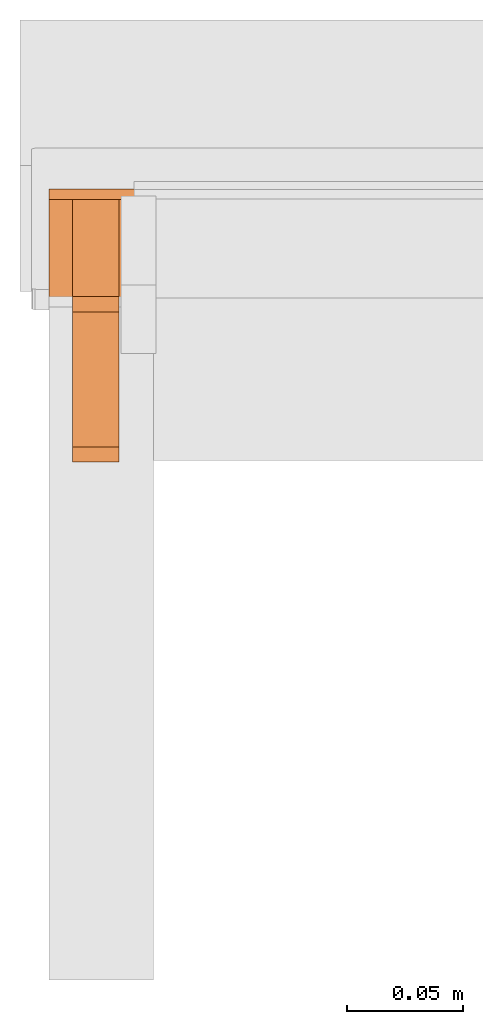
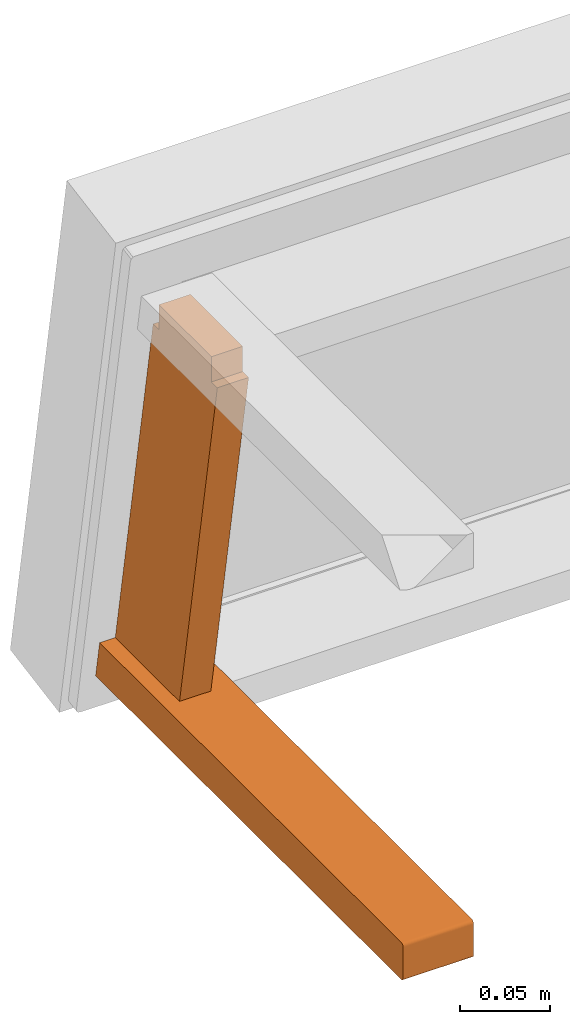
# One storey, part 2 of 5: 2 proxies, 1 element without a shape of its own.
"""IFC2X3 building model written with IfcOpenShell, lengths in metres."""

from ifc_helpers import new_model, si_unit, direction, origin_with_axes, place, context, project, spatial, faceted_brep, source, transform, mapped, element, aggregate, save


model = new_model("IFC2X3")

# Units and contexts
model_context = context("Model", 3, precision=1e-06, world=origin_with_axes(), true_north=direction((0.0, 1.0, 0.0)))
ifc_project = project(units=[si_unit("LENGTHUNIT", "METRE"), si_unit("AREAUNIT", "SQUARE_METRE"), si_unit("VOLUMEUNIT", "CUBIC_METRE")], contexts=[model_context])

# Site, building, storey
site_placement = place(None, origin_with_axes())
site = spatial("IfcSite", under=ifc_project, at=site_placement, CompositionType="ELEMENT")
building_placement = place(site_placement, origin_with_axes())
building = spatial("IfcBuilding", under=site, at=building_placement, Name="Default Building", CompositionType="ELEMENT")
storey_placement = place(building_placement, origin_with_axes())
storey = spatial("IfcBuildingStorey", under=building, at=storey_placement, Name="Default Storey", CompositionType="ELEMENT", Elevation=0.0)

# Assembly, proxies
assembly_placement = place(storey_placement, origin_with_axes())
assembly = element("IfcElementAssembly", 1, at=assembly_placement, inside=storey, Name="Pan H-68-037-A-REV reduced", ObjectType="Pan H-68-037-A-REV reduced", AssemblyPlace="NOTDEFINED", PredefinedType="NOTDEFINED")
shared_shape_1 = source(origin_with_axes(), model_context, "Body", "Brep", [
    faceted_brep([(-0.2150000035762787, -0.04003993049263954, 0.012500000186264515), (-0.2150000035762787, -0.03350000083446503, 0.012500000186264515), (-0.19499999284744263, -0.04003993049263954, 0.012500000186264515), (-0.19499999284744263, -0.04003993049263954, 0.012500000186264515), (-0.2150000035762787, -0.03350000083446503, 0.012500000186264515), (-0.19499999284744263, -0.03350000083446503, 0.012500000186264515), (-0.2150000035762787, -0.03350000083446503, 0.012500000186264515), (-0.2150000035762787, -0.03350000083446503, -0.0044999998062849045), (-0.19499999284744263, -0.03350000083446503, 0.012500000186264515), (-0.19499999284744263, -0.03350000083446503, 0.012500000186264515), (-0.2150000035762787, -0.03350000083446503, -0.0044999998062849045), (-0.19499999284744263, -0.03350000083446503, -0.0044999998062849045), (-0.2150000035762787, -0.03350000083446503, -0.0044999998062849045), (-0.2150000035762787, -0.02850000001490116, -0.0044999998062849045), (-0.19499999284744263, -0.03350000083446503, -0.0044999998062849045), (-0.19499999284744263, -0.03350000083446503, -0.0044999998062849045), (-0.2150000035762787, -0.02850000001490116, -0.0044999998062849045), (-0.19499999284744263, -0.02850000001490116, -0.0044999998062849045), (-0.2150000035762787, -0.02850000001490116, -0.0044999998062849045), (-0.2150000035762787, 0.019500000402331352, -0.0044999998062849045), (-0.19499999284744263, -0.02850000001490116, -0.0044999998062849045), (-0.19499999284744263, -0.02850000001490116, -0.0044999998062849045), (-0.2150000035762787, 0.019500000402331352, -0.0044999998062849045), (-0.19499999284744263, 0.019500000402331352, -0.0044999998062849045), (-0.2150000035762787, 0.019500000402331352, -0.0044999998062849045), (-0.2150000035762787, 0.02449999935925007, -0.0044999998062849045), (-0.19499999284744263, 0.019500000402331352, -0.0044999998062849045), (-0.19499999284744263, 0.019500000402331352, -0.0044999998062849045), (-0.2150000035762787, 0.02449999935925007, -0.0044999998062849045), (-0.19499999284744263, 0.02449999935925007, -0.0044999998062849045), (-0.2150000035762787, 0.02449999935925007, -0.0044999998062849045), (-0.2150000035762787, 0.02449999935925007, 0.012500000186264515), (-0.19499999284744263, 0.02449999935925007, -0.0044999998062849045), (-0.19499999284744263, 0.02449999935925007, -0.0044999998062849045), (-0.2150000035762787, 0.02449999935925007, 0.012500000186264515), (-0.19499999284744263, 0.02449999935925007, 0.012500000186264515), (-0.2150000035762787, 0.02449999935925007, 0.012500000186264515), (-0.2150000035762787, 0.031039930880069733, 0.012500000186264515), (-0.19499999284744263, 0.02449999935925007, 0.012500000186264515), (-0.19499999284744263, 0.02449999935925007, 0.012500000186264515), (-0.2150000035762787, 0.031039930880069733, 0.012500000186264515), (-0.19499999284744263, 0.031039930880069733, 0.012500000186264515), (-0.2150000035762787, 0.031039930880069733, 0.012500000186264515), (-0.2150000035762787, -0.010749737732112408, 0.24950098991394043), (-0.19499999284744263, 0.031039930880069733, 0.012500000186264515), (-0.19499999284744263, 0.031039930880069733, 0.012500000186264515), (-0.2150000035762787, -0.010749737732112408, 0.24950098991394043), (-0.19499999284744263, -0.010749737732112408, 0.24950098991394043), (-0.2150000035762787, -0.010749737732112408, 0.24950098991394043), (-0.2150000035762787, -0.017289668321609497, 0.24950098991394043), (-0.19499999284744263, -0.010749737732112408, 0.24950098991394043), (-0.19499999284744263, -0.010749737732112408, 0.24950098991394043), (-0.2150000035762787, -0.017289668321609497, 0.24950098991394043), (-0.19499999284744263, -0.017289668321609497, 0.24950098991394043), (-0.2150000035762787, -0.017289668321609497, 0.24950098991394043), (-0.2150000035762787, -0.017289668321609497, 0.26650097966194153), (-0.19499999284744263, -0.017289668321609497, 0.24950098991394043), (-0.19499999284744263, -0.017289668321609497, 0.24950098991394043), (-0.2150000035762787, -0.017289668321609497, 0.26650097966194153), (-0.19499999284744263, -0.017289668321609497, 0.26650097966194153), (-0.2150000035762787, -0.017289668321609497, 0.26650097966194153), (-0.2150000035762787, -0.022289669141173363, 0.26650097966194153), (-0.19499999284744263, -0.017289668321609497, 0.26650097966194153), (-0.19499999284744263, -0.017289668321609497, 0.26650097966194153), (-0.2150000035762787, -0.022289669141173363, 0.26650097966194153), (-0.19499999284744263, -0.022289669141173363, 0.26650097966194153), (-0.2150000035762787, -0.022289669141173363, 0.26650097966194153), (-0.2150000035762787, -0.07028967142105103, 0.26650097966194153), (-0.19499999284744263, -0.022289669141173363, 0.26650097966194153), (-0.19499999284744263, -0.022289669141173363, 0.26650097966194153), (-0.2150000035762787, -0.07028967142105103, 0.26650097966194153), (-0.19499999284744263, -0.07028967142105103, 0.26650097966194153), (-0.2150000035762787, -0.07028967142105103, 0.26650097966194153), (-0.2150000035762787, -0.07528966665267944, 0.26650097966194153), (-0.19499999284744263, -0.07028967142105103, 0.26650097966194153), (-0.19499999284744263, -0.07028967142105103, 0.26650097966194153), (-0.2150000035762787, -0.07528966665267944, 0.26650097966194153), (-0.19499999284744263, -0.07528966665267944, 0.26650097966194153), (-0.2150000035762787, -0.07528966665267944, 0.26650097966194153), (-0.2150000035762787, -0.07528966665267944, 0.24950098991394043), (-0.19499999284744263, -0.07528966665267944, 0.26650097966194153), (-0.19499999284744263, -0.07528966665267944, 0.26650097966194153), (-0.2150000035762787, -0.07528966665267944, 0.24950098991394043), (-0.19499999284744263, -0.07528966665267944, 0.24950098991394043), (-0.2150000035762787, -0.07528966665267944, 0.24950098991394043), (-0.2150000035762787, -0.08182960003614426, 0.24950098991394043), (-0.19499999284744263, -0.07528966665267944, 0.24950098991394043), (-0.19499999284744263, -0.07528966665267944, 0.24950098991394043), (-0.2150000035762787, -0.08182960003614426, 0.24950098991394043), (-0.19499999284744263, -0.08182960003614426, 0.24950098991394043), (-0.2150000035762787, -0.08182960003614426, 0.24950098991394043), (-0.2150000035762787, -0.04003993049263954, 0.012500000186264515), (-0.19499999284744263, -0.08182960003614426, 0.24950098991394043), (-0.19499999284744263, -0.08182960003614426, 0.24950098991394043), (-0.2150000035762787, -0.04003993049263954, 0.012500000186264515), (-0.19499999284744263, -0.04003993049263954, 0.012500000186264515), (-0.2150000035762787, -0.017289668321609497, 0.24950098991394043), (-0.2150000035762787, -0.010749737732112408, 0.24950098991394043), (-0.2150000035762787, -0.03350000083446503, 0.012500000186264515), (-0.2150000035762787, -0.010749737732112408, 0.24950098991394043), (-0.2150000035762787, 0.031039930880069733, 0.012500000186264515), (-0.2150000035762787, 0.02449999935925007, 0.012500000186264515), (-0.2150000035762787, -0.04003993049263954, 0.012500000186264515), (-0.2150000035762787, -0.08182960003614426, 0.24950098991394043), (-0.2150000035762787, -0.03350000083446503, 0.012500000186264515), (-0.2150000035762787, -0.03350000083446503, 0.012500000186264515), (-0.2150000035762787, -0.08182960003614426, 0.24950098991394043), (-0.2150000035762787, -0.07528966665267944, 0.24950098991394043), (-0.2150000035762787, -0.03350000083446503, -0.0044999998062849045), (-0.2150000035762787, -0.03350000083446503, 0.012500000186264515), (-0.2150000035762787, -0.02850000001490116, -0.0044999998062849045), (-0.2150000035762787, -0.02850000001490116, -0.0044999998062849045), (-0.2150000035762787, -0.03350000083446503, 0.012500000186264515), (-0.2150000035762787, -0.010749737732112408, 0.24950098991394043), (-0.2150000035762787, -0.02850000001490116, -0.0044999998062849045), (-0.2150000035762787, -0.010749737732112408, 0.24950098991394043), (-0.2150000035762787, 0.019500000402331352, -0.0044999998062849045), (-0.2150000035762787, 0.019500000402331352, -0.0044999998062849045), (-0.2150000035762787, -0.010749737732112408, 0.24950098991394043), (-0.2150000035762787, 0.02449999935925007, 0.012500000186264515), (-0.2150000035762787, 0.019500000402331352, -0.0044999998062849045), (-0.2150000035762787, 0.02449999935925007, 0.012500000186264515), (-0.2150000035762787, 0.02449999935925007, -0.0044999998062849045), (-0.2150000035762787, -0.017289668321609497, 0.26650097966194153), (-0.2150000035762787, -0.017289668321609497, 0.24950098991394043), (-0.2150000035762787, -0.022289669141173363, 0.26650097966194153), (-0.2150000035762787, -0.022289669141173363, 0.26650097966194153), (-0.2150000035762787, -0.017289668321609497, 0.24950098991394043), (-0.2150000035762787, -0.03350000083446503, 0.012500000186264515), (-0.2150000035762787, -0.022289669141173363, 0.26650097966194153), (-0.2150000035762787, -0.03350000083446503, 0.012500000186264515), (-0.2150000035762787, -0.07028967142105103, 0.26650097966194153), (-0.2150000035762787, -0.07028967142105103, 0.26650097966194153), (-0.2150000035762787, -0.03350000083446503, 0.012500000186264515), (-0.2150000035762787, -0.07528966665267944, 0.24950098991394043), (-0.2150000035762787, -0.07028967142105103, 0.26650097966194153), (-0.2150000035762787, -0.07528966665267944, 0.24950098991394043), (-0.2150000035762787, -0.07528966665267944, 0.26650097966194153), (-0.19499999284744263, 0.02449999935925007, 0.012500000186264515), (-0.19499999284744263, 0.031039930880069733, 0.012500000186264515), (-0.19499999284744263, -0.010749737732112408, 0.24950098991394043), (-0.19499999284744263, -0.07528966665267944, 0.24950098991394043), (-0.19499999284744263, -0.08182960003614426, 0.24950098991394043), (-0.19499999284744263, -0.04003993049263954, 0.012500000186264515), (-0.19499999284744263, -0.03350000083446503, 0.012500000186264515), (-0.19499999284744263, -0.010749737732112408, 0.24950098991394043), (-0.19499999284744263, -0.04003993049263954, 0.012500000186264515), (-0.19499999284744263, -0.04003993049263954, 0.012500000186264515), (-0.19499999284744263, -0.010749737732112408, 0.24950098991394043), (-0.19499999284744263, -0.017289668321609497, 0.24950098991394043), (-0.19499999284744263, 0.02449999935925007, -0.0044999998062849045), (-0.19499999284744263, 0.02449999935925007, 0.012500000186264515), (-0.19499999284744263, 0.019500000402331352, -0.0044999998062849045), (-0.19499999284744263, 0.019500000402331352, -0.0044999998062849045), (-0.19499999284744263, 0.02449999935925007, 0.012500000186264515), (-0.19499999284744263, -0.010749737732112408, 0.24950098991394043), (-0.19499999284744263, 0.019500000402331352, -0.0044999998062849045), (-0.19499999284744263, -0.010749737732112408, 0.24950098991394043), (-0.19499999284744263, -0.02850000001490116, -0.0044999998062849045), (-0.19499999284744263, -0.02850000001490116, -0.0044999998062849045), (-0.19499999284744263, -0.010749737732112408, 0.24950098991394043), (-0.19499999284744263, -0.03350000083446503, 0.012500000186264515), (-0.19499999284744263, -0.02850000001490116, -0.0044999998062849045), (-0.19499999284744263, -0.03350000083446503, 0.012500000186264515), (-0.19499999284744263, -0.03350000083446503, -0.0044999998062849045), (-0.19499999284744263, -0.07528966665267944, 0.26650097966194153), (-0.19499999284744263, -0.07528966665267944, 0.24950098991394043), (-0.19499999284744263, -0.07028967142105103, 0.26650097966194153), (-0.19499999284744263, -0.07028967142105103, 0.26650097966194153), (-0.19499999284744263, -0.07528966665267944, 0.24950098991394043), (-0.19499999284744263, -0.04003993049263954, 0.012500000186264515), (-0.19499999284744263, -0.07028967142105103, 0.26650097966194153), (-0.19499999284744263, -0.04003993049263954, 0.012500000186264515), (-0.19499999284744263, -0.022289669141173363, 0.26650097966194153), (-0.19499999284744263, -0.022289669141173363, 0.26650097966194153), (-0.19499999284744263, -0.04003993049263954, 0.012500000186264515), (-0.19499999284744263, -0.017289668321609497, 0.24950098991394043), (-0.19499999284744263, -0.022289669141173363, 0.26650097966194153), (-0.19499999284744263, -0.017289668321609497, 0.24950098991394043), (-0.19499999284744263, -0.017289668321609497, 0.26650097966194153)], [[[0, 1, 2]], [[3, 4, 5]], [[6, 7, 8]], [[9, 10, 11]], [[12, 13, 14]], [[15, 16, 17]], [[18, 19, 20]], [[21, 22, 23]], [[24, 25, 26]], [[27, 28, 29]], [[30, 31, 32]], [[33, 34, 35]], [[36, 37, 38]], [[39, 40, 41]], [[42, 43, 44]], [[45, 46, 47]], [[48, 49, 50]], [[51, 52, 53]], [[54, 55, 56]], [[57, 58, 59]], [[60, 61, 62]], [[63, 64, 65]], [[66, 67, 68]], [[69, 70, 71]], [[72, 73, 74]], [[75, 76, 77]], [[78, 79, 80]], [[81, 82, 83]], [[84, 85, 86]], [[87, 88, 89]], [[90, 91, 92]], [[93, 94, 95]], [[96, 97, 98]], [[99, 100, 101]], [[102, 103, 104]], [[105, 106, 107]], [[108, 109, 110]], [[111, 112, 113]], [[114, 115, 116]], [[117, 118, 119]], [[120, 121, 122]], [[123, 124, 125]], [[126, 127, 128]], [[129, 130, 131]], [[132, 133, 134]], [[135, 136, 137]], [[138, 139, 140]], [[141, 142, 143]], [[144, 145, 146]], [[147, 148, 149]], [[150, 151, 152]], [[153, 154, 155]], [[156, 157, 158]], [[159, 160, 161]], [[162, 163, 164]], [[165, 166, 167]], [[168, 169, 170]], [[171, 172, 173]], [[174, 175, 176]], [[177, 178, 179]]]),
])
proxy_1_placement = place(assembly_placement, origin_with_axes())
proxy_1 = element("IfcBuildingElementProxy", 2, at=proxy_1_placement, Name="17", ObjectType="17", CompositionType="ELEMENT", context=model_context, shape_type="MappedRepresentation", body=[
    mapped(shared_shape_1, transform((0.0, 0.0, 0.0), scale=1.0)),
])
shared_shape_2 = source(origin_with_axes(), model_context, "Body", "Brep", [
    faceted_brep([(-0.22499999403953552, -0.3045358955860138, 0.010499999858438969), (-0.22499999403953552, -0.3045358955860138, -0.010499999858438969), (-0.18000000715255737, -0.3045358955860138, 0.010499999858438969), (-0.18000000715255737, -0.3045358955860138, 0.010499999858438969), (-0.22499999403953552, -0.3045358955860138, -0.010499999858438969), (-0.18000000715255737, -0.3045358955860138, -0.010499999858438969), (-0.22499999403953552, -0.30253592133522034, -0.012500000186264515), (-0.18000000715255737, -0.30253592133522034, -0.012500000186264515), (-0.18000000715255737, -0.3030535578727722, -0.012431851588189602), (-0.22499999403953552, -0.30253592133522034, -0.012500000186264515), (-0.18000000715255737, -0.3030535578727722, -0.012431851588189602), (-0.22499999403953552, -0.3030535578727722, -0.012431851588189602), (-0.22499999403953552, -0.3030535578727722, -0.012431851588189602), (-0.18000000715255737, -0.3030535578727722, -0.012431851588189602), (-0.18000000715255737, -0.30353590846061707, -0.012232051230967045), (-0.22499999403953552, -0.3030535578727722, -0.012431851588189602), (-0.18000000715255737, -0.30353590846061707, -0.012232051230967045), (-0.22499999403953552, -0.30353590846061707, -0.012232051230967045), (-0.22499999403953552, -0.30353590846061707, -0.012232051230967045), (-0.18000000715255737, -0.30353590846061707, -0.012232051230967045), (-0.18000000715255737, -0.30395013093948364, -0.011914213187992573), (-0.22499999403953552, -0.30353590846061707, -0.012232051230967045), (-0.18000000715255737, -0.30395013093948364, -0.011914213187992573), (-0.22499999403953552, -0.30395013093948364, -0.011914213187992573), (-0.22499999403953552, -0.30395013093948364, -0.011914213187992573), (-0.18000000715255737, -0.30395013093948364, -0.011914213187992573), (-0.18000000715255737, -0.3042679727077484, -0.011500000022351742), (-0.22499999403953552, -0.30395013093948364, -0.011914213187992573), (-0.18000000715255737, -0.3042679727077484, -0.011500000022351742), (-0.22499999403953552, -0.3042679727077484, -0.011500000022351742), (-0.22499999403953552, -0.3042679727077484, -0.011500000022351742), (-0.18000000715255737, -0.3042679727077484, -0.011500000022351742), (-0.18000000715255737, -0.3044677674770355, -0.011017638258635998), (-0.22499999403953552, -0.3042679727077484, -0.011500000022351742), (-0.18000000715255737, -0.3044677674770355, -0.011017638258635998), (-0.22499999403953552, -0.3044677674770355, -0.011017638258635998), (-0.22499999403953552, -0.3044677674770355, -0.011017638258635998), (-0.18000000715255737, -0.3044677674770355, -0.011017638258635998), (-0.18000000715255737, -0.3045358955860138, -0.010499999858438969), (-0.22499999403953552, -0.3044677674770355, -0.011017638258635998), (-0.18000000715255737, -0.3045358955860138, -0.010499999858438969), (-0.22499999403953552, -0.3045358955860138, -0.010499999858438969), (-0.22499999403953552, -0.30253592133522034, -0.012500000186264515), (-0.22499999403953552, -0.04950062558054924, -0.012500000186264515), (-0.18000000715255737, -0.30253592133522034, -0.012500000186264515), (-0.18000000715255737, -0.30253592133522034, -0.012500000186264515), (-0.22499999403953552, -0.04950062558054924, -0.012500000186264515), (-0.18000000715255737, -0.04950062558054924, -0.012500000186264515), (-0.22499999403953552, -0.04950062558054924, -0.012500000186264515), (-0.22499999403953552, 0.0354640893638134, -0.012500000186264515), (-0.18000000715255737, -0.04950062558054924, -0.012500000186264515), (-0.18000000715255737, -0.04950062558054924, -0.012500000186264515), (-0.22499999403953552, 0.0354640893638134, -0.012500000186264515), (-0.18000000715255737, 0.0354640893638134, -0.012500000186264515), (-0.22499999403953552, 0.0354640893638134, -0.012500000186264515), (-0.22499999403953552, 0.0351114347577095, -0.010499999858438969), (-0.18000000715255737, 0.0354640893638134, -0.012500000186264515), (-0.18000000715255737, 0.0354640893638134, -0.012500000186264515), (-0.22499999403953552, 0.0351114347577095, -0.010499999858438969), (-0.18000000715255737, 0.0351114347577095, -0.010499999858438969), (-0.22499999403953552, 0.0351114347577095, -0.010499999858438969), (-0.22499999403953552, 0.03140857070684433, 0.010499999858438969), (-0.18000000715255737, 0.0351114347577095, -0.010499999858438969), (-0.18000000715255737, 0.0351114347577095, -0.010499999858438969), (-0.22499999403953552, 0.03140857070684433, 0.010499999858438969), (-0.18000000715255737, 0.03140857070684433, 0.010499999858438969), (-0.22499999403953552, 0.03140857070684433, 0.010499999858438969), (-0.22499999403953552, 0.031055916100740433, 0.012500000186264515), (-0.18000000715255737, 0.03140857070684433, 0.010499999858438969), (-0.18000000715255737, 0.03140857070684433, 0.010499999858438969), (-0.22499999403953552, 0.031055916100740433, 0.012500000186264515), (-0.18000000715255737, 0.031055916100740433, 0.012500000186264515), (-0.22499999403953552, 0.031055916100740433, 0.012500000186264515), (-0.22499999403953552, -0.04950062558054924, 0.012500000186264515), (-0.18000000715255737, 0.031055916100740433, 0.012500000186264515), (-0.18000000715255737, 0.031055916100740433, 0.012500000186264515), (-0.22499999403953552, -0.04950062558054924, 0.012500000186264515), (-0.18000000715255737, -0.04950062558054924, 0.012500000186264515), (-0.22499999403953552, -0.04950062558054924, 0.012500000186264515), (-0.22499999403953552, -0.30253592133522034, 0.012500000186264515), (-0.18000000715255737, -0.04950062558054924, 0.012500000186264515), (-0.18000000715255737, -0.04950062558054924, 0.012500000186264515), (-0.22499999403953552, -0.30253592133522034, 0.012500000186264515), (-0.18000000715255737, -0.30253592133522034, 0.012500000186264515), (-0.22499999403953552, -0.3045358955860138, 0.010499999858438969), (-0.18000000715255737, -0.3045358955860138, 0.010499999858438969), (-0.18000000715255737, -0.3044677674770355, 0.011017638258635998), (-0.22499999403953552, -0.3045358955860138, 0.010499999858438969), (-0.18000000715255737, -0.3044677674770355, 0.011017638258635998), (-0.22499999403953552, -0.3044677674770355, 0.011017638258635998), (-0.22499999403953552, -0.3044677674770355, 0.011017638258635998), (-0.18000000715255737, -0.3044677674770355, 0.011017638258635998), (-0.18000000715255737, -0.3042679727077484, 0.011500000022351742), (-0.22499999403953552, -0.3044677674770355, 0.011017638258635998), (-0.18000000715255737, -0.3042679727077484, 0.011500000022351742), (-0.22499999403953552, -0.3042679727077484, 0.011500000022351742), (-0.22499999403953552, -0.3042679727077484, 0.011500000022351742), (-0.18000000715255737, -0.3042679727077484, 0.011500000022351742), (-0.18000000715255737, -0.30395013093948364, 0.011914213187992573), (-0.22499999403953552, -0.3042679727077484, 0.011500000022351742), (-0.18000000715255737, -0.30395013093948364, 0.011914213187992573), (-0.22499999403953552, -0.30395013093948364, 0.011914213187992573), (-0.22499999403953552, -0.30395013093948364, 0.011914213187992573), (-0.18000000715255737, -0.30395013093948364, 0.011914213187992573), (-0.18000000715255737, -0.30353590846061707, 0.012232051230967045), (-0.22499999403953552, -0.30395013093948364, 0.011914213187992573), (-0.18000000715255737, -0.30353590846061707, 0.012232051230967045), (-0.22499999403953552, -0.30353590846061707, 0.012232051230967045), (-0.22499999403953552, -0.30353590846061707, 0.012232051230967045), (-0.18000000715255737, -0.30353590846061707, 0.012232051230967045), (-0.18000000715255737, -0.3030535578727722, 0.012431851588189602), (-0.22499999403953552, -0.30353590846061707, 0.012232051230967045), (-0.18000000715255737, -0.3030535578727722, 0.012431851588189602), (-0.22499999403953552, -0.3030535578727722, 0.012431851588189602), (-0.22499999403953552, -0.3030535578727722, 0.012431851588189602), (-0.18000000715255737, -0.3030535578727722, 0.012431851588189602), (-0.18000000715255737, -0.30253592133522034, 0.012500000186264515), (-0.22499999403953552, -0.3030535578727722, 0.012431851588189602), (-0.18000000715255737, -0.30253592133522034, 0.012500000186264515), (-0.22499999403953552, -0.30253592133522034, 0.012500000186264515), (-0.22499999403953552, 0.0351114347577095, -0.010499999858438969), (-0.22499999403953552, 0.0354640893638134, -0.012500000186264515), (-0.22499999403953552, -0.04950062558054924, -0.012500000186264515), (-0.22499999403953552, -0.30253592133522034, 0.012500000186264515), (-0.22499999403953552, -0.04950062558054924, 0.012500000186264515), (-0.22499999403953552, -0.04950062558054924, -0.012500000186264515), (-0.22499999403953552, 0.0351114347577095, -0.010499999858438969), (-0.22499999403953552, -0.04950062558054924, -0.012500000186264515), (-0.22499999403953552, 0.03140857070684433, 0.010499999858438969), (-0.22499999403953552, 0.03140857070684433, 0.010499999858438969), (-0.22499999403953552, -0.04950062558054924, -0.012500000186264515), (-0.22499999403953552, -0.04950062558054924, 0.012500000186264515), (-0.22499999403953552, 0.03140857070684433, 0.010499999858438969), (-0.22499999403953552, -0.04950062558054924, 0.012500000186264515), (-0.22499999403953552, 0.031055916100740433, 0.012500000186264515), (-0.22499999403953552, -0.3044677674770355, 0.011017638258635998), (-0.22499999403953552, -0.3042679727077484, 0.011500000022351742), (-0.22499999403953552, -0.30395013093948364, 0.011914213187992573), (-0.22499999403953552, -0.3030535578727722, -0.012431851588189602), (-0.22499999403953552, -0.30353590846061707, -0.012232051230967045), (-0.22499999403953552, -0.3045358955860138, -0.010499999858438969), (-0.22499999403953552, -0.3045358955860138, -0.010499999858438969), (-0.22499999403953552, -0.30353590846061707, -0.012232051230967045), (-0.22499999403953552, -0.30395013093948364, -0.011914213187992573), (-0.22499999403953552, -0.3045358955860138, -0.010499999858438969), (-0.22499999403953552, -0.30395013093948364, -0.011914213187992573), (-0.22499999403953552, -0.3044677674770355, -0.011017638258635998), (-0.22499999403953552, -0.3044677674770355, -0.011017638258635998), (-0.22499999403953552, -0.30395013093948364, -0.011914213187992573), (-0.22499999403953552, -0.3042679727077484, -0.011500000022351742), (-0.22499999403953552, -0.3044677674770355, 0.011017638258635998), (-0.22499999403953552, -0.30395013093948364, 0.011914213187992573), (-0.22499999403953552, -0.3045358955860138, 0.010499999858438969), (-0.22499999403953552, -0.3045358955860138, 0.010499999858438969), (-0.22499999403953552, -0.30395013093948364, 0.011914213187992573), (-0.22499999403953552, -0.30353590846061707, 0.012232051230967045), (-0.22499999403953552, -0.3045358955860138, 0.010499999858438969), (-0.22499999403953552, -0.30353590846061707, 0.012232051230967045), (-0.22499999403953552, -0.3030535578727722, 0.012431851588189602), (-0.22499999403953552, -0.3030535578727722, 0.012431851588189602), (-0.22499999403953552, -0.30253592133522034, 0.012500000186264515), (-0.22499999403953552, -0.3045358955860138, 0.010499999858438969), (-0.22499999403953552, -0.3045358955860138, 0.010499999858438969), (-0.22499999403953552, -0.30253592133522034, 0.012500000186264515), (-0.22499999403953552, -0.04950062558054924, -0.012500000186264515), (-0.22499999403953552, -0.3045358955860138, 0.010499999858438969), (-0.22499999403953552, -0.04950062558054924, -0.012500000186264515), (-0.22499999403953552, -0.3045358955860138, -0.010499999858438969), (-0.22499999403953552, -0.3045358955860138, -0.010499999858438969), (-0.22499999403953552, -0.04950062558054924, -0.012500000186264515), (-0.22499999403953552, -0.30253592133522034, -0.012500000186264515), (-0.22499999403953552, -0.3045358955860138, -0.010499999858438969), (-0.22499999403953552, -0.30253592133522034, -0.012500000186264515), (-0.22499999403953552, -0.3030535578727722, -0.012431851588189602), (-0.18000000715255737, 0.03140857070684433, 0.010499999858438969), (-0.18000000715255737, -0.04950062558054924, -0.012500000186264515), (-0.18000000715255737, 0.0351114347577095, -0.010499999858438969), (-0.18000000715255737, 0.0351114347577095, -0.010499999858438969), (-0.18000000715255737, -0.04950062558054924, -0.012500000186264515), (-0.18000000715255737, 0.0354640893638134, -0.012500000186264515), (-0.18000000715255737, -0.3030535578727722, -0.012431851588189602), (-0.18000000715255737, -0.30253592133522034, -0.012500000186264515), (-0.18000000715255737, -0.3045358955860138, -0.010499999858438969), (-0.18000000715255737, -0.3045358955860138, -0.010499999858438969), (-0.18000000715255737, -0.30253592133522034, -0.012500000186264515), (-0.18000000715255737, -0.04950062558054924, -0.012500000186264515), (-0.18000000715255737, -0.3045358955860138, -0.010499999858438969), (-0.18000000715255737, -0.04950062558054924, -0.012500000186264515), (-0.18000000715255737, -0.3045358955860138, 0.010499999858438969), (-0.18000000715255737, -0.3030535578727722, 0.012431851588189602), (-0.18000000715255737, -0.30353590846061707, 0.012232051230967045), (-0.18000000715255737, -0.3045358955860138, 0.010499999858438969), (-0.18000000715255737, -0.3045358955860138, 0.010499999858438969), (-0.18000000715255737, -0.30353590846061707, 0.012232051230967045), (-0.18000000715255737, -0.30395013093948364, 0.011914213187992573), (-0.18000000715255737, -0.3045358955860138, 0.010499999858438969), (-0.18000000715255737, -0.30395013093948364, 0.011914213187992573), (-0.18000000715255737, -0.3044677674770355, 0.011017638258635998), (-0.18000000715255737, -0.3044677674770355, 0.011017638258635998), (-0.18000000715255737, -0.30395013093948364, 0.011914213187992573), (-0.18000000715255737, -0.3042679727077484, 0.011500000022351742), (-0.18000000715255737, 0.03140857070684433, 0.010499999858438969), (-0.18000000715255737, 0.031055916100740433, 0.012500000186264515), (-0.18000000715255737, -0.04950062558054924, -0.012500000186264515), (-0.18000000715255737, -0.04950062558054924, -0.012500000186264515), (-0.18000000715255737, 0.031055916100740433, 0.012500000186264515), (-0.18000000715255737, -0.04950062558054924, 0.012500000186264515), (-0.18000000715255737, -0.04950062558054924, -0.012500000186264515), (-0.18000000715255737, -0.04950062558054924, 0.012500000186264515), (-0.18000000715255737, -0.3045358955860138, 0.010499999858438969), (-0.18000000715255737, -0.3045358955860138, 0.010499999858438969), (-0.18000000715255737, -0.04950062558054924, 0.012500000186264515), (-0.18000000715255737, -0.30253592133522034, 0.012500000186264515), (-0.18000000715255737, -0.3045358955860138, 0.010499999858438969), (-0.18000000715255737, -0.30253592133522034, 0.012500000186264515), (-0.18000000715255737, -0.3030535578727722, 0.012431851588189602), (-0.18000000715255737, -0.3044677674770355, -0.011017638258635998), (-0.18000000715255737, -0.3042679727077484, -0.011500000022351742), (-0.18000000715255737, -0.30395013093948364, -0.011914213187992573), (-0.18000000715255737, -0.3044677674770355, -0.011017638258635998), (-0.18000000715255737, -0.30395013093948364, -0.011914213187992573), (-0.18000000715255737, -0.3045358955860138, -0.010499999858438969), (-0.18000000715255737, -0.3045358955860138, -0.010499999858438969), (-0.18000000715255737, -0.30395013093948364, -0.011914213187992573), (-0.18000000715255737, -0.30353590846061707, -0.012232051230967045), (-0.18000000715255737, -0.3045358955860138, -0.010499999858438969), (-0.18000000715255737, -0.30353590846061707, -0.012232051230967045), (-0.18000000715255737, -0.3030535578727722, -0.012431851588189602)], [[[0, 1, 2]], [[3, 4, 5]], [[6, 7, 8]], [[9, 10, 11]], [[12, 13, 14]], [[15, 16, 17]], [[18, 19, 20]], [[21, 22, 23]], [[24, 25, 26]], [[27, 28, 29]], [[30, 31, 32]], [[33, 34, 35]], [[36, 37, 38]], [[39, 40, 41]], [[42, 43, 44]], [[45, 46, 47]], [[48, 49, 50]], [[51, 52, 53]], [[54, 55, 56]], [[57, 58, 59]], [[60, 61, 62]], [[63, 64, 65]], [[66, 67, 68]], [[69, 70, 71]], [[72, 73, 74]], [[75, 76, 77]], [[78, 79, 80]], [[81, 82, 83]], [[84, 85, 86]], [[87, 88, 89]], [[90, 91, 92]], [[93, 94, 95]], [[96, 97, 98]], [[99, 100, 101]], [[102, 103, 104]], [[105, 106, 107]], [[108, 109, 110]], [[111, 112, 113]], [[114, 115, 116]], [[117, 118, 119]], [[120, 121, 122]], [[123, 124, 125]], [[126, 127, 128]], [[129, 130, 131]], [[132, 133, 134]], [[135, 136, 137]], [[138, 139, 140]], [[141, 142, 143]], [[144, 145, 146]], [[147, 148, 149]], [[150, 151, 152]], [[153, 154, 155]], [[156, 157, 158]], [[159, 160, 161]], [[162, 163, 164]], [[165, 166, 167]], [[168, 169, 170]], [[171, 172, 173]], [[174, 175, 176]], [[177, 178, 179]], [[180, 181, 182]], [[183, 184, 185]], [[186, 187, 188]], [[189, 190, 191]], [[192, 193, 194]], [[195, 196, 197]], [[198, 199, 200]], [[201, 202, 203]], [[204, 205, 206]], [[207, 208, 209]], [[210, 211, 212]], [[213, 214, 215]], [[216, 217, 218]], [[219, 220, 221]], [[222, 223, 224]], [[225, 226, 227]]]),
])
proxy_2_placement = place(assembly_placement, origin_with_axes())
proxy_2 = element("IfcBuildingElementProxy", 3, at=proxy_2_placement, Name="18", ObjectType="18", CompositionType="ELEMENT", context=model_context, shape_type="MappedRepresentation", body=[
    mapped(shared_shape_2, transform((0.0, 0.0, 0.0), scale=1.0)),
])
aggregate(assembly, [proxy_1, proxy_2])

save(model, "model.ifc")
